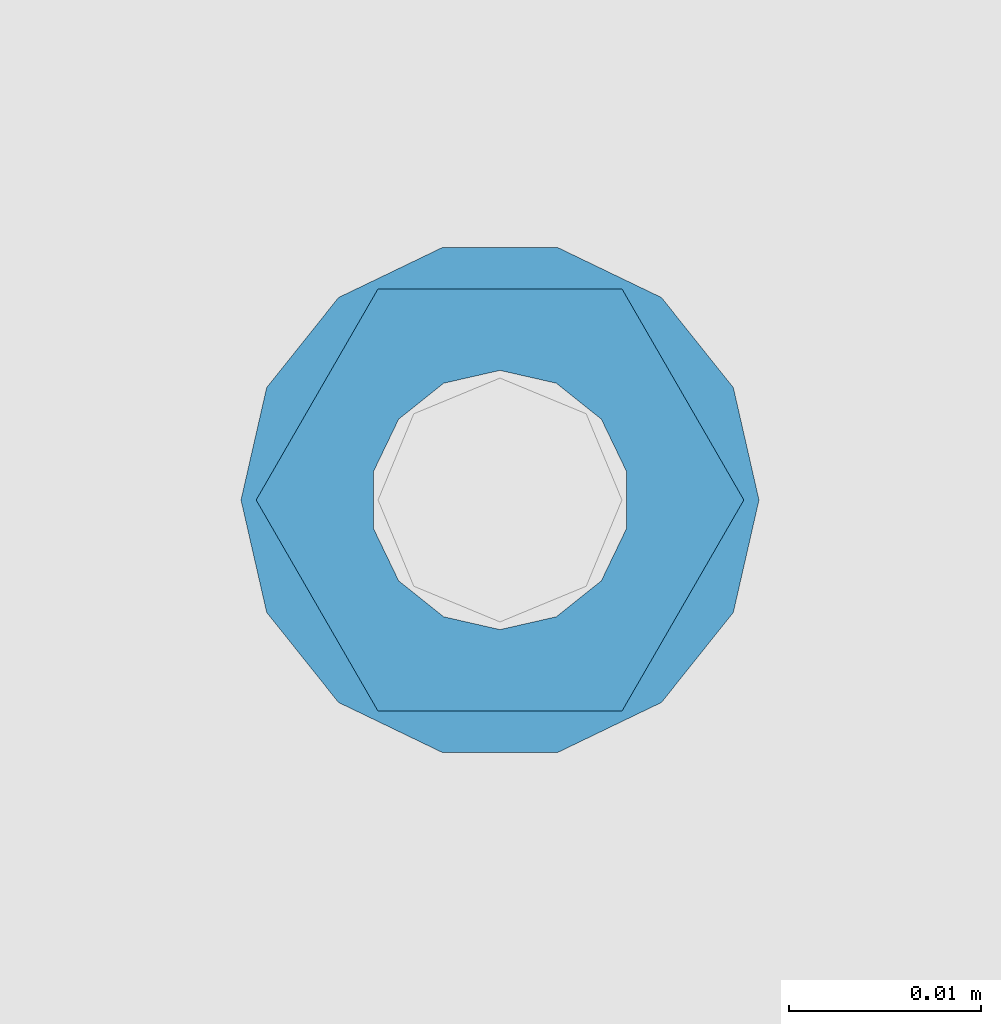
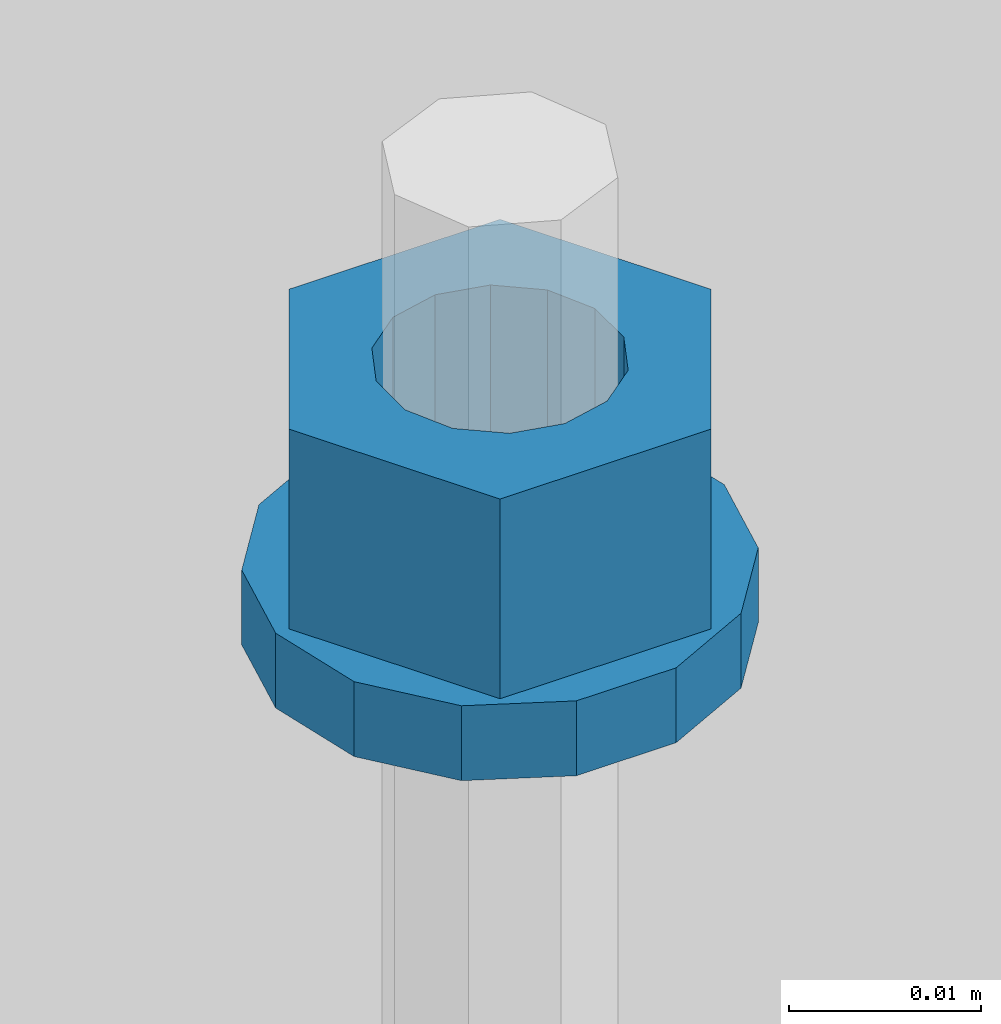
# One storey, part 695 of 1179: 2 columns, 1 element without a shape of its own.
"""IFC2X3 building model written with IfcOpenShell, lengths in millimetres."""

from ifc_helpers import new_model, si_unit, frame, origin_with_axes, place, context, subcontext, project, spatial, faceted_brep, material, type_object, element, aggregate, save


model = new_model("IFC2X3")

# Units and contexts
model_context = context("Model", 3, precision=1e-05, world=origin_with_axes())
body_context = subcontext(model_context, "Body", "Model", "MODEL_VIEW")
ifc_project = project(units=[si_unit("LENGTHUNIT", "METRE", prefix="MILLI"), si_unit("AREAUNIT", "SQUARE_METRE"), si_unit("VOLUMEUNIT", "CUBIC_METRE"), si_unit("MASSUNIT", "GRAM", prefix="KILO"), si_unit("TIMEUNIT", "SECOND"), si_unit("PLANEANGLEUNIT", "RADIAN"), si_unit("SOLIDANGLEUNIT", "STERADIAN"), si_unit("THERMODYNAMICTEMPERATUREUNIT", "DEGREE_CELSIUS"), si_unit("LUMINOUSINTENSITYUNIT", "LUMEN")], contexts=[model_context])

# Site, building, storey
site_placement = place(None, origin_with_axes())
site = spatial("IfcSite", under=ifc_project, at=site_placement, CompositionType="ELEMENT")
building_placement = place(site_placement, origin_with_axes())
building = spatial("IfcBuilding", under=site, at=building_placement, Name="Undefined", CompositionType="ELEMENT")
storey_placement = place(building_placement, origin_with_axes())
storey = spatial("IfcBuildingStorey", under=building, at=storey_placement, Name="Undefined", CompositionType="ELEMENT", Elevation=0.0)

# Assembly, columns
assembly_placement = place(storey_placement, origin_with_axes())
assembly = element("IfcElementAssembly", 1, at=assembly_placement, inside=storey, Name="BEAM", AssemblyPlace="NOTDEFINED", PredefinedType="RIGID_FRAME")
ifc_material = material(Name="STEEL/A307")
column_type_1 = type_object("IfcColumnType", Name="1/2_WASHER", PredefinedType="NOTDEFINED")
column_1_placement = place(assembly_placement, frame((18161.0, 41529.0, 13252.45), z_axis=(0.0, 1.0, 0.0), x_axis=(0.0, 0.0, 1.0)))
column_1 = element("IfcColumn", 2, at=column_1_placement, type_object=column_type_1, material=ifc_material, Name="WASHER", ObjectType="1/2_WASHER", context=body_context, shape_type="Brep", body=[
    faceted_brep([(0.0, -13.4899997711182, 0.0), (0.0, -12.1540698217868, -5.85309154138758), (4.76249999999891, -12.1540698217868, -5.85309154138758), (4.76249999999891, -13.4899997711182, 0.0), (0.0, -8.41087728436833, -10.5469065195466), (4.76249999999891, -8.41087728436833, -10.5469065195466), (0.0, -3.00180734814057, -13.1517773121896), (4.76249999999891, -3.00180734814057, -13.1517773121896), (0.0, 3.00180734814057, -13.1517773121896), (4.76249999999891, 3.00180734814057, -13.1517773121896), (0.0, 8.41087728436833, -10.5469065195466), (4.76249999999891, 8.41087728436833, -10.5469065195466), (0.0, 12.1540698217868, -5.85309154138758), (4.76249999999891, 12.1540698217868, -5.85309154138758), (0.0, 13.4899997711182, 0.0), (4.76249999999891, 13.4899997711182, 0.0), (0.0, 12.1540698217868, 5.85309154138758), (4.76249999999891, 12.1540698217868, 5.85309154138758), (0.0, 8.41087728436833, 10.5469065195466), (4.76249999999891, 8.41087728436833, 10.5469065195466), (0.0, 3.00180734814057, 13.1517773121896), (4.76249999999891, 3.00180734814057, 13.1517773121896), (0.0, -3.00180734814057, 13.1517773121896), (4.76249999999891, -3.00180734814057, 13.1517773121896), (0.0, -8.41087728436833, 10.5469065195466), (4.76249999999891, -8.41087728436833, 10.5469065195466), (0.0, -12.1540698217868, 5.85309154138758), (4.76249999999891, -12.1540698217868, 5.85309154138758), (0.0, 0.0, 6.75), (0.0, 2.9287152390425, 6.08153985834178), (4.76249999999891, 2.9287152390425, 6.08153985834178), (4.76249999999891, 0.0, 6.75), (0.0, 5.27736250665839, 4.2085561625463), (4.76249999999891, 5.27736250665839, 4.2085561625463), (0.0, 6.58076340722619, 1.50201630420543), (4.76249999999891, 6.58076340722619, 1.50201630420543), (0.0, 6.58076340722619, -1.50201630420543), (4.76249999999891, 6.58076340722619, -1.50201630420543), (0.0, 5.27736250665839, -4.2085561625463), (4.76249999999891, 5.27736250665839, -4.2085561625463), (0.0, 2.9287152390425, -6.08153985834088), (4.76249999999891, 2.9287152390425, -6.08153985834088), (0.0, 0.0, -6.75), (4.76249999999891, 0.0, -6.75), (0.0, -2.9287152390425, -6.08153985834178), (4.76249999999891, -2.9287152390425, -6.08153985834178), (0.0, -5.27736250665839, -4.2085561625463), (4.76249999999891, -5.27736250665839, -4.2085561625463), (0.0, -6.58076340722619, -1.50201630420543), (4.76249999999891, -6.58076340722619, -1.50201630420543), (0.0, -6.58076340722619, 1.50201630420543), (4.76249999999891, -6.58076340722619, 1.50201630420543), (0.0, -5.27736250665839, 4.2085561625463), (4.76249999999891, -5.27736250665839, 4.2085561625463), (0.0, -2.9287152390425, 6.08153985834088), (4.76249999999891, -2.9287152390425, 6.08153985834088)], [[[0, 1, 2, 3]], [[1, 4, 5, 2]], [[4, 6, 7, 5]], [[6, 8, 9, 7]], [[8, 10, 11, 9]], [[10, 12, 13, 11]], [[12, 14, 15, 13]], [[14, 16, 17, 15]], [[16, 18, 19, 17]], [[18, 20, 21, 19]], [[20, 22, 23, 21]], [[22, 24, 25, 23]], [[24, 26, 27, 25]], [[26, 0, 3, 27]], [[28, 29, 30, 31]], [[29, 32, 33, 30]], [[32, 34, 35, 33]], [[34, 36, 37, 35]], [[36, 38, 39, 37]], [[38, 40, 41, 39]], [[40, 42, 43, 41]], [[42, 44, 45, 43]], [[44, 46, 47, 45]], [[46, 48, 49, 47]], [[48, 50, 51, 49]], [[50, 52, 53, 51]], [[52, 54, 55, 53]], [[54, 28, 31, 55]], [[5, 7, 9, 11, 13, 15, 17, 19, 21, 23, 25, 27, 3, 2], [33, 35, 37, 39, 41, 43, 45, 47, 49, 51, 53, 55, 31, 30]], [[26, 24, 22, 20, 18, 16, 14, 12, 10, 8, 6, 4, 1, 0], [54, 52, 50, 48, 46, 44, 42, 40, 38, 36, 34, 32, 29, 28]]]),
])
column_type_2 = type_object("IfcColumnType", Name="1/2_HEAVY_HEX_NUT", PredefinedType="NOTDEFINED")
column_2_placement = place(assembly_placement, frame((18161.0, 41529.0, 13257.2125), z_axis=(0.0, 1.0, 0.0), x_axis=(0.0, 0.0, 1.0)))
column_2 = element("IfcColumn", 3, at=column_2_placement, type_object=column_type_2, material=ifc_material, Name="NUT", ObjectType="1/2_HEAVY_HEX_NUT", context=body_context, shape_type="Brep", body=[
    faceted_brep([(0.0, -12.7, 0.0), (0.0, -6.34999990463257, -11.0), (12.7000000000007, -6.34999990463257, -11.0), (12.7000000000007, -12.6999998092651, 0.0), (0.0, 6.34999990463257, -11.0), (12.7000000000007, 6.34999990463257, -11.0), (0.0, 12.7, 0.0), (12.7000000000007, 12.6999998092651, 0.0), (0.0, 6.34999990463257, 11.0), (12.7000000000007, 6.34999990463257, 11.0), (0.0, -6.34999990463257, 11.0), (12.7000000000007, -6.34999990463257, 11.0), (0.0, 0.0, 6.75), (0.0, 2.9287152390425, 6.08153985834178), (12.7000000000007, 2.9287152390425, 6.08153985834178), (12.7000000000007, 0.0, 6.75), (0.0, 5.27736250665839, 4.2085561625463), (12.7000000000007, 5.27736250665839, 4.2085561625463), (0.0, 6.58076340722619, 1.50201630420543), (12.7000000000007, 6.58076340722619, 1.50201630420543), (0.0, 6.58076340722619, -1.50201630420543), (12.7000000000007, 6.58076340722619, -1.50201630420543), (0.0, 5.27736250665839, -4.2085561625463), (12.7000000000007, 5.27736250665839, -4.2085561625463), (0.0, 2.9287152390425, -6.08153985834088), (12.7000000000007, 2.9287152390425, -6.08153985834088), (0.0, 0.0, -6.75), (12.7000000000007, 0.0, -6.75), (0.0, -2.9287152390425, -6.08153985834178), (12.7000000000007, -2.9287152390425, -6.08153985834178), (0.0, -5.27736250665839, -4.2085561625463), (12.7000000000007, -5.27736250665839, -4.2085561625463), (0.0, -6.58076340722619, -1.50201630420543), (12.7000000000007, -6.58076340722619, -1.50201630420543), (0.0, -6.58076340722619, 1.50201630420543), (12.7000000000007, -6.58076340722619, 1.50201630420543), (0.0, -5.27736250665839, 4.2085561625463), (12.7000000000007, -5.27736250665839, 4.2085561625463), (0.0, -2.9287152390425, 6.08153985834088), (12.7000000000007, -2.9287152390425, 6.08153985834088)], [[[0, 1, 2, 3]], [[1, 4, 5, 2]], [[4, 6, 7, 5]], [[6, 8, 9, 7]], [[8, 10, 11, 9]], [[10, 0, 3, 11]], [[12, 13, 14, 15]], [[13, 16, 17, 14]], [[16, 18, 19, 17]], [[18, 20, 21, 19]], [[20, 22, 23, 21]], [[22, 24, 25, 23]], [[24, 26, 27, 25]], [[26, 28, 29, 27]], [[28, 30, 31, 29]], [[30, 32, 33, 31]], [[32, 34, 35, 33]], [[34, 36, 37, 35]], [[36, 38, 39, 37]], [[38, 12, 15, 39]], [[5, 7, 9, 11, 3, 2], [17, 19, 21, 23, 25, 27, 29, 31, 33, 35, 37, 39, 15, 14]], [[10, 8, 6, 4, 1, 0], [38, 36, 34, 32, 30, 28, 26, 24, 22, 20, 18, 16, 13, 12]]]),
])
aggregate(assembly, [column_1, column_2])

save(model, "model.ifc")
